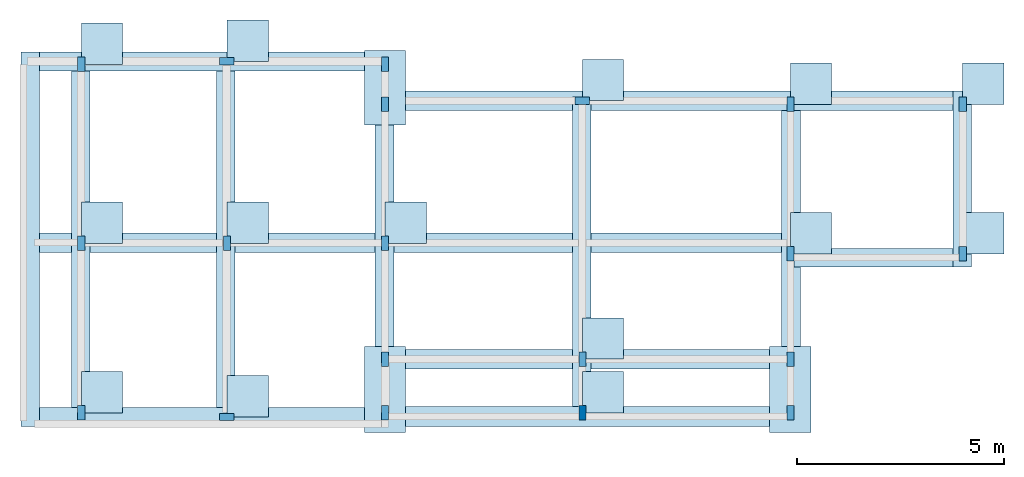
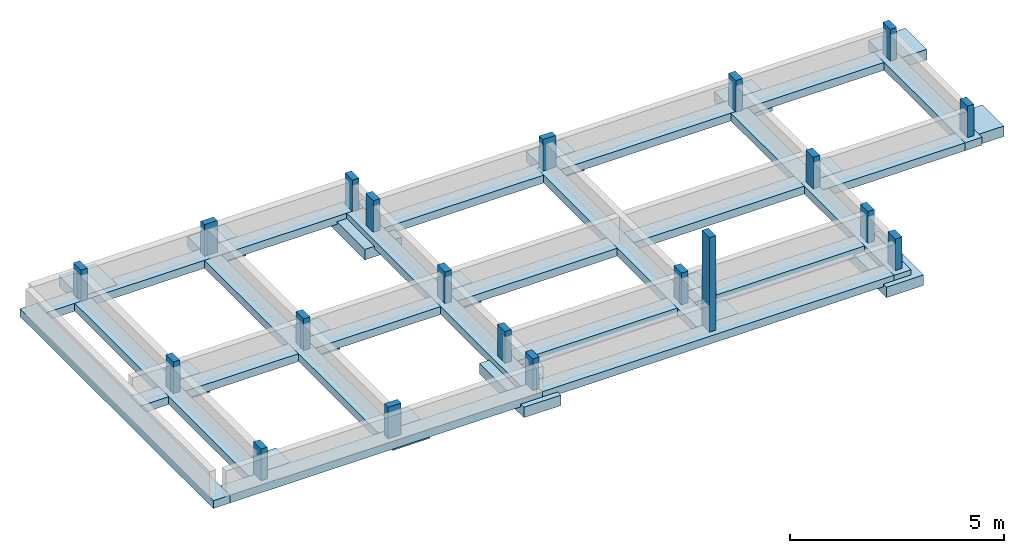
# One storey, part 1 of 2: 31 footings, 20 columns.
"""IFC4 building model written with IfcOpenShell, lengths in millimetres."""

from ifc_helpers import new_model, entity, si_unit, converted_unit, frame, origin_with_axes, origin_2d_with_axis, place, context, subcontext, project, spatial, line, indexed_curve, rectangle, outline, extrude, material, layer, layer_set, layer_usage, material_profile, profile_set, profile_usage, type_object, element, save


model = new_model("IFC4")

# Units and contexts
model_context = context("Model", 3, precision=1e-05, world=origin_with_axes())
plan_context = context("Plan", 2, precision=1e-05, world=origin_2d_with_axis())
body_context = subcontext(model_context, "Body", "Model", "MODEL_VIEW")
ifc_project = project(units=[si_unit("VOLUMEUNIT", "CUBIC_METRE"), si_unit("LENGTHUNIT", "METRE", prefix="MILLI"), converted_unit("PLANEANGLEUNIT", "degree", entity("IfcReal", 0.0174532925199433), si_unit("PLANEANGLEUNIT", "RADIAN"), dimensions=[0, 0, 0, 0, 0, 0, 0]), si_unit("AREAUNIT", "SQUARE_METRE")], contexts=[model_context, plan_context])

# Site, building, storey
site_placement = place(None, origin_with_axes())
site = spatial("IfcSite", under=ifc_project, at=site_placement)
building_placement = place(site_placement, origin_with_axes())
building = spatial("IfcBuilding", under=site, at=building_placement, Name="Building")
storey_placement = place(building_placement, frame((0.0, 0.0, -900.000035762787), z_axis=(0.0, 0.0, 1.0), x_axis=(1.0, 0.0, 0.0)))
storey = spatial("IfcBuildingStorey", under=building, at=storey_placement, Name="FOUNDATION")

# Footings
ifc_material_1 = material(Name="Concrete Reinforced", Category="Concrete")
ifc_layer_1 = layer(ifc_material_1, 300.0, Name="Column Footing Layer", Category="Structure", Priority=1)
ifc_layer_set_1 = layer_set([ifc_layer_1], Name="FTG-2LYR")
ifc_layer_usage_1 = layer_usage(ifc_layer_set_1, "AXIS3", "POSITIVE", 0.0)
slab_type_1 = type_object("IfcSlabType", Name="FLR250", PredefinedType="NOTDEFINED", material=ifc_layer_set_1)
footing_1_placement = place(storey_placement, frame((3896.79956436157, 11282.9618453979, -449.999988079071), z_axis=(0.0, 0.0, 1.0), x_axis=(1.0, 0.0, 0.0)))
element("IfcFooting", 1, at=footing_1_placement, inside=storey, type_object=slab_type_1, material=ifc_layer_usage_1, PredefinedType="PAD_FOOTING", context=body_context, shape_type="SweptSolid", body=[
    extrude(outline(indexed_curve([(0.0, 0.0), (1000.0, 0.0), (1000.0, 1000.0), (0.0, 1000.0), (0.0, 0.0)])), None, (0.0, 0.0, 1.0), 300.0),
])
ifc_layer_usage_2 = layer_usage(ifc_layer_set_1, "AXIS3", "POSITIVE", 0.0)
footing_2_placement = place(storey_placement, frame((3896.79718017578, 7667.17338562012, -449.999988079071), z_axis=(0.0, 0.0, 1.0), x_axis=(1.0, 0.0, 0.0)))
element("IfcFooting", 2, at=footing_2_placement, inside=storey, type_object=slab_type_1, material=ifc_layer_usage_2, PredefinedType="PAD_FOOTING", context=body_context, shape_type="SweptSolid", body=[
    extrude(outline(indexed_curve([(0.0, 0.0), (1000.0, 0.0), (1000.0, 1000.0), (0.0, 1000.0), (0.0, 0.0)])), None, (0.0, 0.0, 1.0), 300.0),
])
ifc_layer_usage_3 = layer_usage(ifc_layer_set_1, "AXIS3", "POSITIVE", 0.0)
footing_3_placement = place(storey_placement, frame((-270.760536193848, 11282.9627990723, -449.999988079071), z_axis=(0.0, 0.0, 1.0), x_axis=(1.0, 0.0, 0.0)))
element("IfcFooting", 3, at=footing_3_placement, inside=storey, type_object=slab_type_1, material=ifc_layer_usage_3, PredefinedType="PAD_FOOTING", context=body_context, shape_type="SweptSolid", body=[
    extrude(outline(indexed_curve([(0.0, 0.0), (1000.0, 0.0), (1000.0, 1000.0), (0.0, 1000.0), (0.0, 0.0)])), None, (0.0, 0.0, 1.0), 300.0),
])
ifc_layer_usage_4 = layer_usage(ifc_layer_set_1, "AXIS3", "POSITIVE", 0.0)
footing_4_placement = place(storey_placement, frame((-270.761251449585, 7667.17338562012, -450.00010728836), z_axis=(0.0, 0.0, 1.0), x_axis=(1.0, 0.0, 0.0)))
element("IfcFooting", 4, at=footing_4_placement, inside=storey, type_object=slab_type_1, material=ifc_layer_usage_4, PredefinedType="PAD_FOOTING", context=body_context, shape_type="SweptSolid", body=[
    extrude(outline(indexed_curve([(0.0, 0.0), (1000.0, 0.0), (1000.0, 1000.0), (0.0, 1000.0), (0.0, 0.0)])), None, (0.0, 0.0, 1.0), 300.0),
])
ifc_layer_usage_5 = layer_usage(ifc_layer_set_1, "AXIS3", "POSITIVE", 0.0)
footing_5_placement = place(storey_placement, frame((-10076.4207839966, 11282.9647064209, -449.999988079071), z_axis=(0.0, 0.0, 1.0), x_axis=(1.0, 0.0, 0.0)))
element("IfcFooting", 5, at=footing_5_placement, inside=storey, type_object=slab_type_1, material=ifc_layer_usage_5, PredefinedType="PAD_FOOTING", context=body_context, shape_type="SweptSolid", body=[
    extrude(outline(indexed_curve([(499.999701976776, 1305.83202838898), (499.999701976776, -500.000298023224), (-500.000298023224, -500.000298023224), (-500.000298023224, 1305.83202838898)], segments=[line(3, 2), line(2, 1), line(1, 4), line(4, 3)], self_intersect=False)), None, (0.0, 0.0, 1.0), 300.0),
])
ifc_layer_usage_6 = layer_usage(ifc_layer_set_1, "AXIS3", "POSITIVE", 0.0)
footing_6_placement = place(storey_placement, frame((-10076.4207839966, 7920.10688781738, -449.999988079071), z_axis=(0.0, 0.0, 1.0), x_axis=(1.0, 0.0, 0.0)))
element("IfcFooting", 6, at=footing_6_placement, inside=storey, type_object=slab_type_1, material=ifc_layer_usage_6, PredefinedType="PAD_FOOTING", context=body_context, shape_type="SweptSolid", body=[
    extrude(outline(indexed_curve([(0.0, 0.0), (1000.0, 0.0), (1000.0, 1000.0), (0.0, 1000.0), (0.0, 0.0)])), None, (0.0, 0.0, 1.0), 300.0),
])
ifc_layer_usage_7 = layer_usage(ifc_layer_set_1, "AXIS3", "POSITIVE", 0.0)
footing_7_placement = place(storey_placement, frame((-17423.3932495117, 3816.9527053833, -449.999988079071), z_axis=(0.0, 0.0, 1.0), x_axis=(1.0, 0.0, 0.0)))
element("IfcFooting", 7, at=footing_7_placement, inside=storey, type_object=slab_type_1, material=ifc_layer_usage_7, PredefinedType="PAD_FOOTING", context=body_context, shape_type="SweptSolid", body=[
    extrude(outline(indexed_curve([(0.0, 0.0), (1000.0, 0.0), (1000.0, 1000.0), (0.0, 1000.0), (0.0, 0.0)])), None, (0.0, 0.0, 1.0), 300.0),
])
ifc_layer_usage_8 = layer_usage(ifc_layer_set_1, "AXIS3", "POSITIVE", 0.0)
footing_8_placement = place(storey_placement, frame((-17423.3932495117, 7920.10641098022, -450.00010728836), z_axis=(0.0, 0.0, 1.0), x_axis=(1.0, 0.0, 0.0)))
element("IfcFooting", 8, at=footing_8_placement, inside=storey, type_object=slab_type_1, material=ifc_layer_usage_8, PredefinedType="PAD_FOOTING", context=body_context, shape_type="SweptSolid", body=[
    extrude(outline(indexed_curve([(0.0, 0.0), (1000.0, 0.0), (1000.0, 1000.0), (0.0, 1000.0), (0.0, 0.0)])), None, (0.0, 0.0, 1.0), 300.0),
])
ifc_layer_usage_9 = layer_usage(ifc_layer_set_1, "AXIS3", "POSITIVE", 0.0)
footing_9_placement = place(storey_placement, frame((-17423.3951568604, 12249.9666213989, -300.000131130218), z_axis=(0.0, 0.0, 1.0), x_axis=(1.0, 0.0, 0.0)))
element("IfcFooting", 9, at=footing_9_placement, inside=storey, type_object=slab_type_1, material=ifc_layer_usage_9, PredefinedType="PAD_FOOTING", context=body_context, shape_type="SweptSolid", body=[
    extrude(outline(indexed_curve([(0.0, 0.0), (1000.0, 0.0), (1000.0, 1000.0), (0.0, 1000.0), (0.0, 0.0)])), None, (0.0, 0.0, 1.0), 300.0),
])
ifc_layer_usage_10 = layer_usage(ifc_layer_set_1, "AXIS3", "POSITIVE", 0.0)
footing_10_placement = place(storey_placement, frame((-5303.73001098633, 11370.4633712769, -449.999988079071), z_axis=(0.0, 0.0, 1.0), x_axis=(1.0, 0.0, 0.0)))
element("IfcFooting", 10, at=footing_10_placement, inside=storey, type_object=slab_type_1, material=ifc_layer_usage_10, Name="FLR250", PredefinedType="PAD_FOOTING", context=body_context, shape_type="SweptSolid", body=[
    extrude(outline(indexed_curve([(0.0, 0.0), (1000.0, 0.0), (1000.0, 1000.0), (0.0, 1000.0), (0.0, 0.0)])), None, (0.0, 0.0, 1.0), 300.0),
])
ifc_layer_usage_11 = layer_usage(ifc_layer_set_1, "AXIS3", "POSITIVE", 0.0)
footing_11_placement = place(storey_placement, frame((-10076.4207839966, 3979.23231124878, -449.999988079071), z_axis=(0.0, 0.0, 1.0), x_axis=(1.0, 0.0, 0.0)))
element("IfcFooting", 11, at=footing_11_placement, inside=storey, type_object=slab_type_1, material=ifc_layer_usage_11, PredefinedType="PAD_FOOTING", context=body_context, shape_type="SweptSolid", body=[
    extrude(outline(indexed_curve([(-500.000298023224, -635.232746601105), (499.999701976776, -635.232746601105), (499.999701976776, 1444.3553686142), (-500.000298023224, 1444.3553686142)], segments=[line(3, 2), line(2, 1), line(1, 4), line(4, 3)], self_intersect=False)), None, (0.0, 0.0, 1.0), 300.0),
])
ifc_layer_usage_12 = layer_usage(ifc_layer_set_1, "AXIS3", "POSITIVE", 0.0)
footing_12_placement = place(storey_placement, frame((-13901.5274047852, 7920.10736465454, -449.999988079071), z_axis=(0.0, 0.0, 1.0), x_axis=(1.0, 0.0, 0.0)))
element("IfcFooting", 12, at=footing_12_placement, inside=storey, type_object=slab_type_1, material=ifc_layer_usage_12, PredefinedType="PAD_FOOTING", context=body_context, shape_type="SweptSolid", body=[
    extrude(outline(indexed_curve([(0.0, 0.0), (1000.0, 0.0), (1000.0, 1000.0), (0.0, 1000.0), (0.0, 0.0)])), None, (0.0, 0.0, 1.0), 300.0),
])
ifc_layer_usage_13 = layer_usage(ifc_layer_set_1, "AXIS3", "POSITIVE", 0.0)
footing_13_placement = place(storey_placement, frame((-13901.5264511108, 12321.8698501587, -449.999988079071), z_axis=(0.0, 0.0, 1.0), x_axis=(1.0, 0.0, 0.0)))
element("IfcFooting", 13, at=footing_13_placement, inside=storey, type_object=slab_type_1, material=ifc_layer_usage_13, PredefinedType="PAD_FOOTING", context=body_context, shape_type="SweptSolid", body=[
    extrude(outline(indexed_curve([(0.0, 0.0), (1000.0, 0.0), (1000.0, 1000.0), (0.0, 1000.0), (0.0, 0.0)])), None, (0.0, 0.0, 1.0), 300.0),
])
ifc_layer_usage_14 = layer_usage(ifc_layer_set_1, "AXIS3", "POSITIVE", 0.0)
footing_14_placement = place(storey_placement, frame((-13901.5264511108, 3719.88868713379, -449.999988079071), z_axis=(0.0, 0.0, 1.0), x_axis=(1.0, 0.0, 0.0)))
element("IfcFooting", 14, at=footing_14_placement, inside=storey, type_object=slab_type_1, material=ifc_layer_usage_14, PredefinedType="PAD_FOOTING", context=body_context, shape_type="SweptSolid", body=[
    extrude(outline(indexed_curve([(0.0, 0.0), (1000.0, 0.0), (1000.0, 1000.0), (0.0, 1000.0), (0.0, 0.0)])), None, (0.0, 0.0, 1.0), 300.0),
])
ifc_layer_usage_15 = layer_usage(ifc_layer_set_1, "AXIS3", "POSITIVE", 0.0)
footing_15_placement = place(storey_placement, frame((-270.761489868164, 3979.23231124878, -449.999988079071), z_axis=(0.0, 0.0, 1.0), x_axis=(1.0, 0.0, 0.0)))
element("IfcFooting", 15, at=footing_15_placement, inside=storey, type_object=slab_type_1, material=ifc_layer_usage_15, PredefinedType="PAD_FOOTING", context=body_context, shape_type="SweptSolid", body=[
    extrude(outline(indexed_curve([(-500.000298023224, -635.232746601105), (499.999701976776, -635.232746601105), (499.999701976776, 1444.3553686142), (-500.000298023224, 1444.3553686142)], segments=[line(3, 2), line(2, 1), line(1, 4), line(4, 3)], self_intersect=False)), None, (0.0, 0.0, 1.0), 300.0),
])
ifc_layer_usage_16 = layer_usage(ifc_layer_set_1, "AXIS3", "POSITIVE", 0.0)
footing_16_placement = place(storey_placement, frame((-5302.34050750732, 5116.31536483765, -449.999988079071), z_axis=(0.0, 0.0, 1.0), x_axis=(1.0, 0.0, 0.0)))
element("IfcFooting", 16, at=footing_16_placement, inside=storey, type_object=slab_type_1, material=ifc_layer_usage_16, PredefinedType="PAD_FOOTING", context=body_context, shape_type="SweptSolid", body=[
    extrude(outline(indexed_curve([(0.0, 0.0), (1000.0, 0.0), (1000.0, 1000.0), (0.0, 1000.0), (0.0, 0.0)])), None, (0.0, 0.0, 1.0), 300.0),
])
ifc_layer_usage_17 = layer_usage(ifc_layer_set_1, "AXIS3", "POSITIVE", 0.0)
footing_17_placement = place(storey_placement, frame((-5305.45234680176, 3816.95055961609, -449.999988079071), z_axis=(0.0, 0.0, 1.0), x_axis=(1.0, 0.0, 0.0)))
element("IfcFooting", 17, at=footing_17_placement, inside=storey, type_object=slab_type_1, material=ifc_layer_usage_17, Name="FLR250", PredefinedType="PAD_FOOTING", context=body_context, shape_type="SweptSolid", body=[
    extrude(outline(indexed_curve([(0.0, 0.0), (1000.0, 0.0), (1000.0, 1000.0), (0.0, 1000.0), (0.0, 0.0)])), None, (0.0, 0.0, 1.0), 300.0),
])
ifc_material_2 = material(Name="Concrete cast-in-situ", Category="Concrete")
ifc_layer_2 = layer(ifc_material_2, 225.0, Name="Wall Footing Layer", Category="Structure", Priority=1)
ifc_layer_set_2 = layer_set([ifc_layer_2], Name="SLB-FTG225-1LYR")
ifc_layer_usage_18 = layer_usage(ifc_layer_set_2, "AXIS3", "POSITIVE", 0.0)
slab_type_2 = type_object("IfcSlabType", Name="FTG225", PredefinedType="USERDEFINED", material=ifc_layer_set_2)
footing_18_placement = place(storey_placement, frame((-18731.8954467773, 3491.95957183838, -224.999964237213), z_axis=(0.0, 0.0, 1.0), x_axis=(1.0, 0.0, 0.0)))
element("IfcFooting", 18, at=footing_18_placement, inside=storey, type_object=slab_type_2, material=ifc_layer_usage_18, Name="FTG225", PredefinedType="STRIP_FOOTING", context=body_context, shape_type="SweptSolid", body=[
    extrude(outline(indexed_curve([(8742.97332763672, 450.000047683716), (8742.97332763672, 0.0), (301.401138305664, 0.0), (301.401138305664, 450.000047683716)], segments=[line(3, 2), line(2, 1), line(1, 4), line(4, 3)], self_intersect=False)), None, (0.0, 0.0, 1.0), 225.0),
])
ifc_layer_usage_19 = layer_usage(ifc_layer_set_2, "AXIS3", "POSITIVE", 0.0)
footing_19_placement = place(storey_placement, frame((-9988.92211914062, 4874.95851516724, -224.999964237213), z_axis=(0.0, 0.0, 1.0), x_axis=(1.0, 0.0, 0.0)))
element("IfcFooting", 19, at=footing_19_placement, inside=storey, type_object=slab_type_2, material=ifc_layer_usage_19, PredefinedType="STRIP_FOOTING", context=body_context, shape_type="SweptSolid", body=[
    extrude(outline(indexed_curve([(129.10270690918, 0.0), (9505.66005706787, 0.0), (9505.66005706787, 475.735008716583), (129.10270690918, 475.735008716583)], segments=[line(3, 2), line(2, 1), line(1, 4), line(4, 3)], self_intersect=False)), None, (0.0, 0.0, 1.0), 225.0),
])
ifc_layer_usage_20 = layer_usage(ifc_layer_set_2, "AXIS3", "POSITIVE", 0.0)
footing_20_placement = place(storey_placement, frame((-483.26188325882, 3491.95957183838, -224.999964237213), z_axis=(0.0, 0.0, 1.0), x_axis=(1.0, 0.0, 0.0)))
element("IfcFooting", 20, at=footing_20_placement, inside=storey, type_object=slab_type_2, material=ifc_layer_usage_20, PredefinedType="STRIP_FOOTING", context=body_context, shape_type="SweptSolid", body=[
    extrude(outline(indexed_curve([(454.10218834877, 7641.00551605225), (454.10218834877, 0.0), (0.0, 0.0), (0.0, 7641.00551605225)], segments=[line(3, 2), line(2, 1), line(1, 4), line(4, 3)], self_intersect=False)), None, (0.0, 0.0, 1.0), 225.0),
])
ifc_layer_usage_21 = layer_usage(ifc_layer_set_2, "AXIS3", "POSITIVE", 0.0)
footing_21_placement = place(storey_placement, frame((-183.26136469841, 7342.17500686646, -224.999964237213), z_axis=(0.0, 0.0, 1.0), x_axis=(1.0, 0.0, 0.0)))
element("IfcFooting", 21, at=footing_21_placement, inside=storey, type_object=slab_type_2, material=ifc_layer_usage_21, PredefinedType="STRIP_FOOTING", context=body_context, shape_type="SweptSolid", body=[
    extrude(outline(indexed_curve([(3842.55528450012, 449.999898672104), (3842.55528450012, 0.0), (0.0, 0.0), (0.0, 449.999898672104)], segments=[line(3, 2), line(2, 1), line(1, 4), line(4, 3)], self_intersect=False)), None, (0.0, 0.0, 1.0), 225.0),
])
ifc_layer_usage_22 = layer_usage(ifc_layer_set_2, "AXIS3", "POSITIVE", 0.0)
footing_22_placement = place(storey_placement, frame((-9988.92211914062, 3491.95957183838, -224.999964237213), z_axis=(0.0, 0.0, 1.0), x_axis=(1.0, 0.0, 0.0)))
element("IfcFooting", 22, at=footing_22_placement, inside=storey, type_object=slab_type_2, material=ifc_layer_usage_22, PredefinedType="STRIP_FOOTING", context=body_context, shape_type="SweptSolid", body=[
    extrude(outline(indexed_curve([(9505.66005706787, 475.735008716583), (9505.66005706787, 0.0), (0.0, 0.0), (0.0, 475.735008716583)], segments=[line(3, 2), line(2, 1), line(1, 4), line(4, 3)], self_intersect=False)), None, (0.0, 0.0, 1.0), 225.0),
])
ifc_layer_usage_23 = layer_usage(ifc_layer_set_2, "AXIS3", "POSITIVE", 0.0)
footing_23_placement = place(storey_placement, frame((-9988.92211914062, 7691.96128845215, -224.999964237213), z_axis=(0.0, 0.0, 1.0), x_axis=(1.0, 0.0, 0.0)))
element("IfcFooting", 23, at=footing_23_placement, inside=storey, type_object=slab_type_2, material=ifc_layer_usage_23, PredefinedType="STRIP_FOOTING", context=body_context, shape_type="SweptSolid", body=[
    extrude(outline(indexed_curve([(-8742.97332763672, 0.0), (9505.66005706787, 0.0), (9505.66005706787, 475.735008716583), (-8742.97332763672, 475.735008716583)], segments=[line(3, 2), line(2, 1), line(1, 4), line(4, 3)], self_intersect=False)), None, (0.0, 0.0, 1.0), 225.0),
])
ifc_layer_usage_24 = layer_usage(ifc_layer_set_2, "AXIS3", "POSITIVE", 0.0)
footing_24_placement = place(storey_placement, frame((-5542.95206069946, 3491.95957183838, -224.999964237213), z_axis=(0.0, 0.0, 1.0), x_axis=(1.0, 0.0, 0.0)))
element("IfcFooting", 24, at=footing_24_placement, inside=storey, type_object=slab_type_2, material=ifc_layer_usage_24, PredefinedType="STRIP_FOOTING", context=body_context, shape_type="SweptSolid", body=[
    extrude(outline(indexed_curve([(454.10218834877, 7966.00437164307), (454.10218834877, 475.734949111938), (0.0, 475.734949111938), (0.0, 7966.00437164307)], segments=[line(3, 2), line(2, 1), line(1, 4), line(4, 3)], self_intersect=False)), None, (0.0, 0.0, 1.0), 225.0),
])
ifc_layer_usage_25 = layer_usage(ifc_layer_set_2, "AXIS3", "POSITIVE", 0.0)
footing_25_placement = place(storey_placement, frame((-10313.9219284058, 3491.95957183838, -224.999964237213), z_axis=(0.0, 0.0, 1.0), x_axis=(1.0, 0.0, 0.0)))
element("IfcFooting", 25, at=footing_25_placement, inside=storey, type_object=slab_type_2, material=ifc_layer_usage_25, PredefinedType="STRIP_FOOTING", context=body_context, shape_type="SweptSolid", body=[
    extrude(outline(indexed_curve([(454.10218834877, 8600.00896453857), (454.10218834877, 450.000047683716), (0.0, 450.000047683716), (0.0, 8600.00896453857)], segments=[line(3, 2), line(2, 1), line(1, 4), line(4, 3)], self_intersect=False)), None, (0.0, 0.0, 1.0), 225.0),
])
ifc_layer_usage_26 = layer_usage(ifc_layer_set_2, "AXIS3", "POSITIVE", 0.0)
footing_26_placement = place(storey_placement, frame((-9988.92211914062, 11132.9650878906, -224.999964237213), z_axis=(0.0, 0.0, 1.0), x_axis=(1.0, 0.0, 0.0)))
element("IfcFooting", 26, at=footing_26_placement, inside=storey, type_object=slab_type_2, material=ifc_layer_usage_26, PredefinedType="STRIP_FOOTING", context=body_context, shape_type="SweptSolid", body=[
    extrude(outline(indexed_curve([(13648.2162475586, 475.735008716583), (13648.2162475586, 0.0), (129.10270690918, 0.0), (129.10270690918, 475.735008716583)], segments=[line(3, 2), line(2, 1), line(1, 4), line(4, 3)], self_intersect=False)), None, (0.0, 0.0, 1.0), 225.0),
])
ifc_layer_usage_27 = layer_usage(ifc_layer_set_2, "AXIS3", "POSITIVE", 0.0)
footing_27_placement = place(storey_placement, frame((-18731.8954467773, 12091.968536377, -224.999964237213), z_axis=(0.0, 0.0, 1.0), x_axis=(1.0, 0.0, 0.0)))
element("IfcFooting", 27, at=footing_27_placement, inside=storey, type_object=slab_type_2, material=ifc_layer_usage_27, Name="FTG225", PredefinedType="STRIP_FOOTING", context=body_context, shape_type="SweptSolid", body=[
    extrude(outline(indexed_curve([(301.401138305664, 0.0), (8872.0760345459, 0.0), (8872.0760345459, 450.000047683716), (301.401138305664, 450.000047683716)], segments=[line(3, 2), line(2, 1), line(1, 4), line(4, 3)], self_intersect=False)), None, (0.0, 0.0, 1.0), 225.0),
])
ifc_layer_usage_28 = layer_usage(ifc_layer_set_2, "AXIS3", "POSITIVE", 0.0)
footing_28_placement = place(storey_placement, frame((-14155.5252075195, 3491.95957183838, -224.999964237213), z_axis=(0.0, 0.0, 1.0), x_axis=(1.0, 0.0, 0.0)))
element("IfcFooting", 28, at=footing_28_placement, inside=storey, type_object=slab_type_2, material=ifc_layer_usage_28, PredefinedType="STRIP_FOOTING", context=body_context, shape_type="SweptSolid", body=[
    extrude(outline(indexed_curve([(454.10218834877, 8600.00896453857), (454.10218834877, 450.000047683716), (0.0, 450.000047683716), (0.0, 8600.00896453857)], segments=[line(3, 2), line(2, 1), line(1, 4), line(4, 3)], self_intersect=False)), None, (0.0, 0.0, 1.0), 225.0),
])
ifc_layer_usage_29 = layer_usage(ifc_layer_set_2, "AXIS3", "POSITIVE", 0.0)
footing_29_placement = place(storey_placement, frame((-18884.5958709717, 3491.95957183838, -224.999964237213), z_axis=(0.0, 0.0, 1.0), x_axis=(1.0, 0.0, 0.0)))
element("IfcFooting", 29, at=footing_29_placement, inside=storey, type_object=slab_type_2, material=ifc_layer_usage_29, PredefinedType="STRIP_FOOTING", context=body_context, shape_type="SweptSolid", body=[
    extrude(outline(indexed_curve([(454.10218834877, 9050.00877380371), (454.10218834877, -2.98023223876953e-05), (0.0, -2.98023223876953e-05), (0.0, 9050.00877380371)], segments=[line(3, 2), line(2, 1), line(1, 4), line(4, 3)], self_intersect=False)), None, (0.0, 0.0, 1.0), 225.0),
])
ifc_layer_usage_30 = layer_usage(ifc_layer_set_2, "AXIS3", "POSITIVE", 0.0)
footing_30_placement = place(storey_placement, frame((3659.29388999939, 7342.17548370361, -224.999964237213), z_axis=(0.0, 0.0, 1.0), x_axis=(1.0, 0.0, 0.0)))
element("IfcFooting", 30, at=footing_30_placement, inside=storey, type_object=slab_type_2, material=ifc_layer_usage_30, Name="FTG225", PredefinedType="STRIP_FOOTING", context=body_context, shape_type="SweptSolid", body=[
    extrude(outline(indexed_curve([(0.0, 0.0), (454.10218834877, 0.0), (454.10218834877, 4266.52431488037), (0.0, 4266.52431488037)], segments=[line(3, 2), line(2, 1), line(1, 4), line(4, 3)], self_intersect=False)), None, (0.0, 0.0, 1.0), 225.0),
])
ifc_layer_usage_31 = layer_usage(ifc_layer_set_2, "AXIS3", "POSITIVE", 0.0)
footing_31_placement = place(storey_placement, frame((-17664.8941040039, 3491.95957183838, -224.999964237213), z_axis=(0.0, 0.0, 1.0), x_axis=(1.0, 0.0, 0.0)))
element("IfcFooting", 31, at=footing_31_placement, inside=storey, type_object=slab_type_2, material=ifc_layer_usage_31, PredefinedType="STRIP_FOOTING", context=body_context, shape_type="SweptSolid", body=[
    extrude(outline(indexed_curve([(454.10218834877, 8600.00896453857), (454.10218834877, 450.000047683716), (0.0, 450.000047683716), (0.0, 8600.00896453857)], segments=[line(3, 2), line(2, 1), line(1, 4), line(4, 3)], self_intersect=False)), None, (0.0, 0.0, 1.0), 225.0),
])

# Columns
ifc_material_profile = material_profile(ifc_material_1, rectangle(XDim=175.0, YDim=350.0), Category="Structure", Priority=1)
ifc_profile_set = profile_set([ifc_material_profile], Name="COL_1LYR")
ifc_profile_usage_1 = profile_usage(ifc_profile_set, cardinal=5)
column_type = type_object("IfcColumnType", Name="C175x350", PredefinedType="NOTDEFINED", material=ifc_profile_set)
column_1_placement = place(storey_placement, frame((3896.79932594299, 11282.9627990723, -300.000011920929), z_axis=(0.0, 0.0, 1.0), x_axis=(1.0, 0.0, 0.0)))
element("IfcColumn", 32, at=column_1_placement, inside=storey, type_object=column_type, material=ifc_profile_usage_1, Name="C175x350", context=body_context, shape_type="SweptSolid", body=[
    extrude(rectangle(XDim=175.0, YDim=350.0), origin_with_axes(), (0.0, 0.0, 1.0), 1200.00002384186),
])
ifc_profile_usage_2 = profile_usage(ifc_profile_set, cardinal=5)
column_2_placement = place(storey_placement, frame((3896.79932594299, 7667.17386245728, -300.000011920929), z_axis=(0.0, 0.0, 1.0), x_axis=(1.0, 0.0, 0.0)))
element("IfcColumn", 33, at=column_2_placement, inside=storey, type_object=column_type, material=ifc_profile_usage_2, Name="C175x350", context=body_context, shape_type="SweptSolid", body=[
    extrude(rectangle(XDim=175.0, YDim=350.0), origin_with_axes(), (0.0, 0.0, 1.0), 1200.00002384186),
])
ifc_profile_usage_3 = profile_usage(ifc_profile_set, cardinal=5)
column_3_placement = place(storey_placement, frame((-270.761251449585, 11282.9627990723, -300.000011920929), z_axis=(0.0, 0.0, 1.0), x_axis=(1.0, 0.0, 0.0)))
element("IfcColumn", 34, at=column_3_placement, inside=storey, type_object=column_type, material=ifc_profile_usage_3, Name="C175x350", context=body_context, shape_type="SweptSolid", body=[
    extrude(rectangle(XDim=175.0, YDim=350.0), origin_with_axes(), (0.0, 0.0, 1.0), 1200.00002384186),
])
ifc_profile_usage_4 = profile_usage(ifc_profile_set, cardinal=5)
column_4_placement = place(storey_placement, frame((-270.761251449585, 7667.17386245728, -300.000011920929), z_axis=(0.0, 0.0, 1.0), x_axis=(1.0, 0.0, 0.0)))
element("IfcColumn", 35, at=column_4_placement, inside=storey, type_object=column_type, material=ifc_profile_usage_4, Name="C175x350", context=body_context, shape_type="SweptSolid", body=[
    extrude(rectangle(XDim=175.0, YDim=350.0), origin_with_axes(), (0.0, 0.0, 1.0), 1200.00002384186),
])
ifc_profile_usage_5 = profile_usage(ifc_profile_set, cardinal=5)
column_5_placement = place(storey_placement, frame((-270.761251449585, 3816.94841384888, -300.000011920929), z_axis=(0.0, 0.0, 1.0), x_axis=(1.0, 0.0, 0.0)))
element("IfcColumn", 36, at=column_5_placement, inside=storey, type_object=column_type, material=ifc_profile_usage_5, Name="C175x350", context=body_context, shape_type="SweptSolid", body=[
    extrude(rectangle(XDim=175.0, YDim=350.0), origin_with_axes(), (0.0, 0.0, 1.0), 1200.00002384186),
])
ifc_profile_usage_6 = profile_usage(ifc_profile_set, cardinal=5)
column_6_placement = place(storey_placement, frame((-10076.4207839966, 7920.10688781738, -300.000011920929), z_axis=(0.0, 0.0, 1.0), x_axis=(1.0, 0.0, 0.0)))
element("IfcColumn", 37, at=column_6_placement, inside=storey, type_object=column_type, material=ifc_profile_usage_6, Name="C175x350", context=body_context, shape_type="SweptSolid", body=[
    extrude(rectangle(XDim=175.0, YDim=350.0), origin_with_axes(), (0.0, 0.0, 1.0), 1200.00002384186),
])
ifc_profile_usage_7 = profile_usage(ifc_profile_set, cardinal=5)
column_7_placement = place(storey_placement, frame((-10076.4207839966, 3816.95294380188, -300.000011920929), z_axis=(0.0, 0.0, 1.0), x_axis=(1.0, 0.0, 0.0)))
element("IfcColumn", 38, at=column_7_placement, inside=storey, type_object=column_type, material=ifc_profile_usage_7, Name="C175x350", context=body_context, shape_type="SweptSolid", body=[
    extrude(rectangle(XDim=175.0, YDim=350.0), origin_with_axes(), (0.0, 0.0, 1.0), 1200.00002384186),
])
ifc_profile_usage_8 = profile_usage(ifc_profile_set, cardinal=5)
column_8_placement = place(storey_placement, frame((-10076.4207839966, 11282.9647064209, -300.000011920929), z_axis=(0.0, 0.0, 1.0), x_axis=(1.0, 0.0, 0.0)))
element("IfcColumn", 39, at=column_8_placement, inside=storey, type_object=column_type, material=ifc_profile_usage_8, Name="C175x350", context=body_context, shape_type="SweptSolid", body=[
    extrude(rectangle(XDim=175.0, YDim=350.0), origin_with_axes(), (0.0, 0.0, 1.0), 1200.00002384186),
])
ifc_profile_usage_9 = profile_usage(ifc_profile_set, cardinal=5)
column_9_placement = place(storey_placement, frame((-10076.4188766479, 12249.9628067017, -300.000011920929), z_axis=(0.0, 0.0, 1.0), x_axis=(1.0, 0.0, 0.0)))
element("IfcColumn", 40, at=column_9_placement, inside=storey, type_object=column_type, material=ifc_profile_usage_9, Name="C175x350", context=body_context, shape_type="SweptSolid", body=[
    extrude(rectangle(XDim=175.0, YDim=350.0), origin_with_axes(), (0.0, 0.0, 1.0), 1200.00002384186),
])
ifc_profile_usage_10 = profile_usage(ifc_profile_set, cardinal=5)
column_10_placement = place(storey_placement, frame((-17423.3932495117, 3816.95294380188, -300.000011920929), z_axis=(0.0, 0.0, 1.0), x_axis=(1.0, 0.0, 0.0)))
element("IfcColumn", 41, at=column_10_placement, inside=storey, type_object=column_type, material=ifc_profile_usage_10, Name="C175x350", context=body_context, shape_type="SweptSolid", body=[
    extrude(rectangle(XDim=175.0, YDim=350.0), origin_with_axes(), (0.0, 0.0, 1.0), 1200.00002384186),
])
ifc_profile_usage_11 = profile_usage(ifc_profile_set, cardinal=5)
column_11_placement = place(storey_placement, frame((-17423.3932495117, 7920.10688781738, -300.000011920929), z_axis=(0.0, 0.0, 1.0), x_axis=(1.0, 0.0, 0.0)))
element("IfcColumn", 42, at=column_11_placement, inside=storey, type_object=column_type, material=ifc_profile_usage_11, Name="C175x350", context=body_context, shape_type="SweptSolid", body=[
    extrude(rectangle(XDim=175.0, YDim=350.0), origin_with_axes(), (0.0, 0.0, 1.0), 1200.00002384186),
])
ifc_profile_usage_12 = profile_usage(ifc_profile_set, cardinal=5)
column_12_placement = place(storey_placement, frame((-17423.3932495117, 12249.9656677246, -300.000011920929), z_axis=(0.0, 0.0, 1.0), x_axis=(1.0, 0.0, 0.0)))
element("IfcColumn", 43, at=column_12_placement, inside=storey, type_object=column_type, material=ifc_profile_usage_12, Name="C175x350", context=body_context, shape_type="SweptSolid", body=[
    extrude(rectangle(XDim=175.0, YDim=350.0), origin_with_axes(), (0.0, 0.0, 1.0), 1200.00002384186),
])
ifc_profile_usage_13 = profile_usage(ifc_profile_set, cardinal=5)
column_13_placement = place(storey_placement, frame((-5303.73001098633, 11370.4633712769, -300.000011920929), z_axis=(0.0, 0.0, 1.0), x_axis=(7.54979012640431e-08, -0.999999999999997, 0.0)))
element("IfcColumn", 44, at=column_13_placement, inside=storey, type_object=column_type, material=ifc_profile_usage_13, Name="C175x350", context=body_context, shape_type="SweptSolid", body=[
    extrude(rectangle(XDim=175.0, YDim=350.0), origin_with_axes(), (0.0, 0.0, 1.0), 1200.00002384186),
])
ifc_profile_usage_14 = profile_usage(ifc_profile_set, cardinal=5)
column_14_placement = place(storey_placement, frame((-13901.5264511108, 7920.10688781738, -300.000011920929), z_axis=(0.0, 0.0, 1.0), x_axis=(1.0, 0.0, 0.0)))
element("IfcColumn", 45, at=column_14_placement, inside=storey, type_object=column_type, material=ifc_profile_usage_14, Name="C175x350", context=body_context, shape_type="SweptSolid", body=[
    extrude(rectangle(XDim=175.0, YDim=350.0), origin_with_axes(), (0.0, 0.0, 1.0), 1200.00002384186),
])
ifc_profile_usage_15 = profile_usage(ifc_profile_set, cardinal=5)
column_15_placement = place(storey_placement, frame((-13901.5264511108, 12321.8688964844, -300.000011920929), z_axis=(0.0, 0.0, 1.0), x_axis=(-4.37113882867379e-08, -0.999999999999999, 0.0)))
element("IfcColumn", 46, at=column_15_placement, inside=storey, type_object=column_type, material=ifc_profile_usage_15, Name="C175x350", context=body_context, shape_type="SweptSolid", body=[
    extrude(rectangle(XDim=175.0, YDim=350.0), origin_with_axes(), (0.0, 0.0, 1.0), 1200.00002384186),
])
ifc_profile_usage_16 = profile_usage(ifc_profile_set, cardinal=5)
column_16_placement = place(storey_placement, frame((-13901.5264511108, 3719.88868713379, -300.000011920929), z_axis=(0.0, 0.0, 1.0), x_axis=(-4.37113882867379e-08, -0.999999999999999, 0.0)))
element("IfcColumn", 47, at=column_16_placement, inside=storey, type_object=column_type, material=ifc_profile_usage_16, Name="C175x350", context=body_context, shape_type="SweptSolid", body=[
    extrude(rectangle(XDim=175.0, YDim=350.0), origin_with_axes(), (0.0, 0.0, 1.0), 1200.00002384186),
])
ifc_profile_usage_17 = profile_usage(ifc_profile_set, cardinal=5)
column_17_placement = place(storey_placement, frame((-10076.4207839966, 5112.4587059021, -300.000011920929), z_axis=(0.0, 0.0, 1.0), x_axis=(1.0, 0.0, 0.0)))
element("IfcColumn", 48, at=column_17_placement, inside=storey, type_object=column_type, material=ifc_profile_usage_17, Name="C175x350", context=body_context, shape_type="SweptSolid", body=[
    extrude(rectangle(XDim=175.0, YDim=350.0), origin_with_axes(), (0.0, 0.0, 1.0), 1200.00002384186),
])
ifc_profile_usage_18 = profile_usage(ifc_profile_set, cardinal=5)
column_18_placement = place(storey_placement, frame((-270.761489868164, 5112.4587059021, -300.000011920929), z_axis=(0.0, 0.0, 1.0), x_axis=(1.0, 0.0, 0.0)))
element("IfcColumn", 49, at=column_18_placement, inside=storey, type_object=column_type, material=ifc_profile_usage_18, Name="C175x350", context=body_context, shape_type="SweptSolid", body=[
    extrude(rectangle(XDim=175.0, YDim=350.0), origin_with_axes(), (0.0, 0.0, 1.0), 1200.00002384186),
])
ifc_profile_usage_19 = profile_usage(ifc_profile_set, cardinal=5)
column_19_placement = place(storey_placement, frame((-5302.34098434448, 5116.31536483765, -300.000011920929), z_axis=(0.0, 0.0, 1.0), x_axis=(1.0, 0.0, 0.0)))
element("IfcColumn", 50, at=column_19_placement, inside=storey, type_object=column_type, material=ifc_profile_usage_19, Name="C175x350", context=body_context, shape_type="SweptSolid", body=[
    extrude(rectangle(XDim=175.0, YDim=350.0), origin_with_axes(), (0.0, 0.0, 1.0), 1200.00002384186),
])
ifc_profile_usage_20 = profile_usage(ifc_profile_set, cardinal=5)
column_20_placement = place(storey_placement, frame((-5302.34146118164, 3816.94841384888, -300.000011920929), z_axis=(0.0, 0.0, 1.0), x_axis=(1.0, 0.0, 0.0)))
element("IfcColumn", 51, at=column_20_placement, inside=storey, type_object=column_type, material=ifc_profile_usage_20, Name="C175x350", context=body_context, shape_type="SweptSolid", body=[
    extrude(rectangle(XDim=175.0, YDim=350.0), origin_with_axes(), (0.0, 0.0, 1.0), 3000.0),
])

save(model, "model.ifc")
